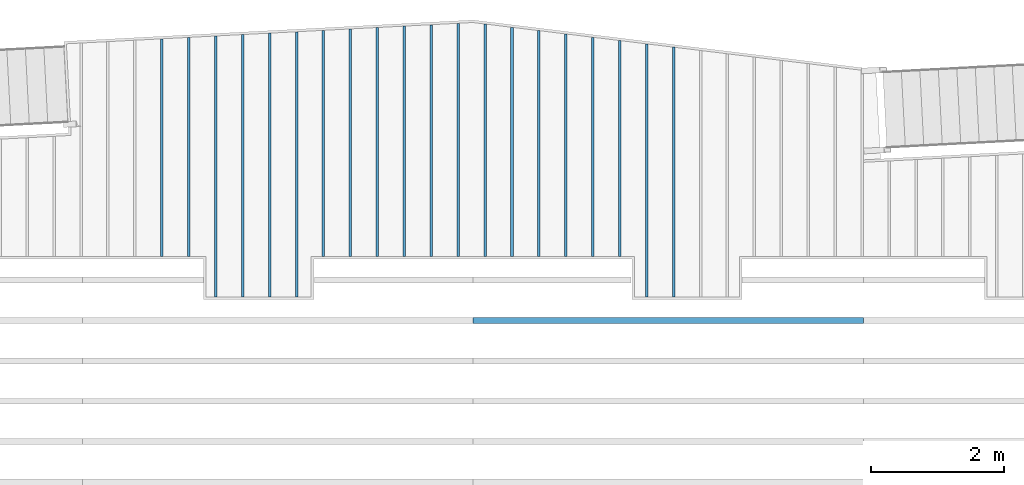
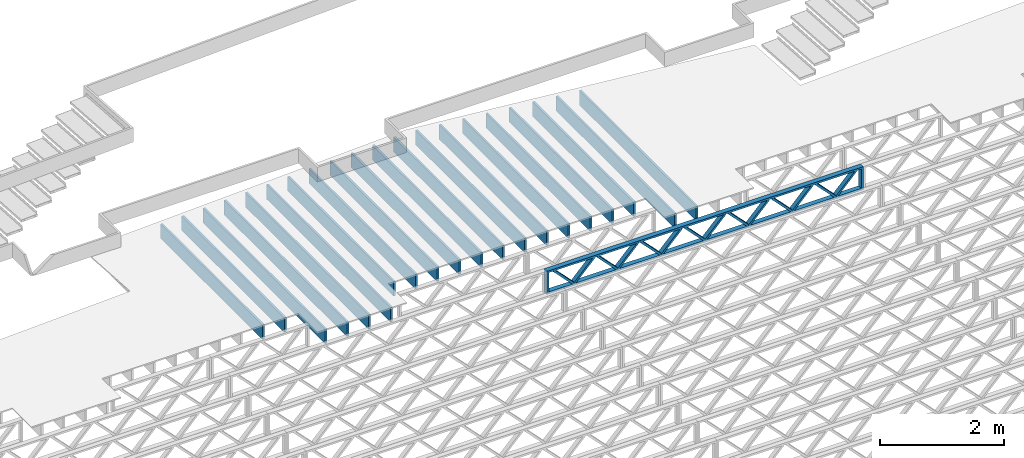
# One storey, part 8 of 23: 21 beams, 2 elements without a shape of their own.
"""IFC4 building model written with IfcOpenShell, lengths in feet."""

from ifc_helpers import new_model, entity, si_unit, converted_unit, derived_unit, direction, frame, frame_2d, origin, origin_2d_with_axis, place, context, subcontext, project, spatial, rectangle, extrude, source, transform, mapped, material, material_profile, profile_set, profile_usage, type_object, type_shapes, element, aggregate, save


model = new_model("IFC4")

# Units and contexts
model_context = context("Model", 3, precision=0.0001, world=origin(), true_north=direction((6.12303176911189e-17, 1.0)))
body_context = subcontext(model_context, "Body", "Model", "MODEL_VIEW")
ifc_project = project(units=[converted_unit("LENGTHUNIT", "FOOT", entity("IfcRatioMeasure", 0.3048), si_unit("LENGTHUNIT", "METRE"), dimensions=[1, 0, 0, 0, 0, 0, 0]), converted_unit("AREAUNIT", "SQUARE FOOT", entity("IfcRatioMeasure", 0.09290304), si_unit("AREAUNIT", "SQUARE_METRE"), dimensions=[2, 0, 0, 0, 0, 0, 0]), converted_unit("VOLUMEUNIT", "CUBIC FOOT", entity("IfcRatioMeasure", 0.028316846592), si_unit("VOLUMEUNIT", "CUBIC_METRE"), dimensions=[3, 0, 0, 0, 0, 0, 0]), converted_unit("PLANEANGLEUNIT", "DEGREE", entity("IfcRatioMeasure", 0.0174532925199433), si_unit("PLANEANGLEUNIT", "RADIAN"), dimensions=[0, 0, 0, 0, 0, 0, 0]), si_unit("MASSUNIT", "GRAM", prefix="KILO"), derived_unit("MASSDENSITYUNIT", [(si_unit("MASSUNIT", "GRAM", prefix="KILO"), 1), (si_unit("LENGTHUNIT", "METRE"), -3)]), derived_unit("MOMENTOFINERTIAUNIT", [(si_unit("LENGTHUNIT", "METRE"), 4)]), si_unit("TIMEUNIT", "SECOND"), si_unit("FREQUENCYUNIT", "HERTZ"), si_unit("THERMODYNAMICTEMPERATUREUNIT", "DEGREE_CELSIUS"), derived_unit("THERMALTRANSMITTANCEUNIT", [(si_unit("MASSUNIT", "GRAM", prefix="KILO"), 1), (si_unit("THERMODYNAMICTEMPERATUREUNIT", "KELVIN"), -1), (si_unit("TIMEUNIT", "SECOND"), -3)]), derived_unit("VOLUMETRICFLOWRATEUNIT", [(si_unit("LENGTHUNIT", "METRE"), 3), (si_unit("TIMEUNIT", "SECOND"), -1)]), si_unit("ELECTRICCURRENTUNIT", "AMPERE"), si_unit("ELECTRICVOLTAGEUNIT", "VOLT"), si_unit("POWERUNIT", "WATT"), si_unit("FORCEUNIT", "NEWTON"), si_unit("ILLUMINANCEUNIT", "LUX"), si_unit("LUMINOUSFLUXUNIT", "LUMEN"), si_unit("LUMINOUSINTENSITYUNIT", "CANDELA"), derived_unit("USERDEFINED", [(si_unit("MASSUNIT", "GRAM", prefix="KILO"), -1), (si_unit("LENGTHUNIT", "METRE"), -2), (si_unit("TIMEUNIT", "SECOND"), 3), (si_unit("LUMINOUSFLUXUNIT", "LUMEN"), 1)]), derived_unit("LINEARVELOCITYUNIT", [(si_unit("LENGTHUNIT", "METRE"), 1), (si_unit("TIMEUNIT", "SECOND"), -1)]), si_unit("PRESSUREUNIT", "PASCAL"), derived_unit("USERDEFINED", [(si_unit("LENGTHUNIT", "METRE"), -2), (si_unit("MASSUNIT", "GRAM", prefix="KILO"), 1), (si_unit("TIMEUNIT", "SECOND"), -2)]), derived_unit("LINEARFORCEUNIT", [(si_unit("MASSUNIT", "GRAM", prefix="KILO"), 1), (si_unit("LENGTHUNIT", "METRE"), 1), (si_unit("TIMEUNIT", "SECOND"), -2), (si_unit("LENGTHUNIT", "METRE"), -1)]), derived_unit("PLANARFORCEUNIT", [(si_unit("MASSUNIT", "GRAM", prefix="KILO"), 1), (si_unit("LENGTHUNIT", "METRE"), 1), (si_unit("TIMEUNIT", "SECOND"), -2), (si_unit("LENGTHUNIT", "METRE"), -2)])], contexts=[model_context])

# Site, building, storey
site_placement = place(None, origin())
site = spatial("IfcSite", under=ifc_project, at=site_placement, CompositionType="ELEMENT")
building_placement = place(site_placement, origin())
building = spatial("IfcBuilding", under=site, at=building_placement, CompositionType="ELEMENT")
storey_placement = place(building_placement, frame((0.0, 0.0, 10.8020833333333)))
storey = spatial("IfcBuildingStorey", under=building, at=storey_placement, Name="2ND FLOOR", CompositionType="ELEMENT", Elevation=10.8020833333333)

# Assembly, beam
assembly_1_placement = place(storey_placement, origin())
assembly_1 = element("IfcElementAssembly", 1, at=assembly_1_placement, inside=storey, Name="Structural Beam System:Structural Framing System", ObjectType="Structural Beam System:Structural Framing System", AssemblyPlace="NOTDEFINED", PredefinedType="BEAM_GRID")
ifc_material_1 = material(Name="WOOD TRUSS", Category="Materials")
ifc_material_profile_1 = material_profile(ifc_material_1, rectangle(XDim=1.73473973950632, YDim=0.125, at=frame_2d((-1.11022302462516e-16, 8.32667268468867e-17), x_axis=(1.0, 0.0))))
ifc_material_profile_2 = material_profile(ifc_material_1, rectangle(XDim=1.73473973950633, YDim=0.125, at=frame_2d((-1.11022302462516e-16, 8.32667268468867e-17), x_axis=(1.0, 0.0))))
ifc_material_profile_3 = material_profile(ifc_material_1, rectangle(XDim=1.73473973950632, YDim=0.125, at=frame_2d((-5.55111512312578e-17, 1.38777878078145e-16), x_axis=(1.0, 0.0))))
ifc_material_profile_4 = material_profile(ifc_material_1, rectangle(XDim=1.73473973950633, YDim=0.125, at=frame_2d((-1.11022302462516e-16, 8.32667268468867e-17), x_axis=(1.0, 0.0))))
ifc_material_profile_5 = material_profile(ifc_material_1, rectangle(XDim=1.73473973950632, YDim=0.125, at=frame_2d((-1.11022302462516e-16, 8.32667268468867e-17), x_axis=(1.0, 0.0))))
ifc_material_profile_6 = material_profile(ifc_material_1, rectangle(XDim=1.73473973950633, YDim=0.125, at=frame_2d((-2.77555756156289e-16, 3.05311331771918e-16), x_axis=(1.0, 0.0))))
ifc_material_profile_7 = material_profile(ifc_material_1, rectangle(XDim=1.73473973950632, YDim=0.124999999999999, at=frame_2d((-3.88578058618805e-16, -2.4980018054066e-16), x_axis=(1.0, 0.0))))
ifc_material_profile_8 = material_profile(ifc_material_1, rectangle(XDim=1.73473973950633, YDim=0.125, at=frame_2d((2.77555756156289e-16, -3.05311331771918e-16), x_axis=(1.0, 0.0))))
ifc_material_profile_9 = material_profile(ifc_material_1, rectangle(XDim=1.73473973950632, YDim=0.124999999999999, at=frame_2d((-1.11022302462516e-16, 8.32667268468867e-17), x_axis=(1.0, 0.0))))
ifc_material_profile_10 = material_profile(ifc_material_1, rectangle(XDim=1.73473973950633, YDim=0.125, at=origin_2d_with_axis()))
ifc_material_profile_11 = material_profile(ifc_material_1, rectangle(XDim=0.124999999999982, YDim=0.291666666666668, at=origin_2d_with_axis()))
ifc_material_profile_12 = material_profile(ifc_material_1, rectangle(XDim=0.124999999999932, YDim=0.291666666666664, at=origin_2d_with_axis()))
ifc_material_profile_13 = material_profile(ifc_material_1, rectangle(XDim=1.25000000000002, YDim=0.29166666666667, at=origin_2d_with_axis()))
ifc_material_profile_14 = material_profile(ifc_material_1, rectangle(XDim=1.25000000000004, YDim=0.291666666666667, at=origin_2d_with_axis()))
ifc_profile_set_1 = profile_set([ifc_material_profile_1, ifc_material_profile_2, ifc_material_profile_3, ifc_material_profile_4, ifc_material_profile_5, ifc_material_profile_6, ifc_material_profile_7, ifc_material_profile_8, ifc_material_profile_9, ifc_material_profile_10, ifc_material_profile_11, ifc_material_profile_12, ifc_material_profile_13, ifc_material_profile_14])
ifc_profile_usage_1 = profile_usage(ifc_profile_set_1, cardinal=8)
beam_type_1 = type_object("IfcBeamType", PredefinedType="BEAM", material=ifc_profile_set_1)
shared_shape_1 = source(origin(), body_context, "Body", "SweptSolid", [
    extrude(rectangle(XDim=1.73473973950632, YDim=0.124999999999999, at=frame_2d((5.55111512312578e-16, 7.21644966006352e-16), x_axis=(1.0, 0.0))), frame((5.95847627016989, -0.145833333333334, 0.0), z_axis=(0.0, 1.0, 0.0), x_axis=(0.693383046997606, 0.0, 0.720569184836762)), (0.0, 0.0, 1.0), 0.291666666666667),
    extrude(rectangle(XDim=1.73473973950633, YDim=0.125, at=origin_2d_with_axis()), frame((4.70819039649662, -0.145833333333334, 0.0), z_axis=(0.0, 1.0, 0.0), x_axis=(0.69338304699761, 0.0, -0.720569184836758)), (0.0, 0.0, 1.0), 0.291666666666666),
    extrude(rectangle(XDim=1.73473973950632, YDim=0.125, at=frame_2d((2.22044604925031e-16, 3.88578058618805e-16), x_axis=(1.0, 0.0))), frame((3.29180960350342, -0.145833333333334, 0.0), z_axis=(0.0, 1.0, 0.0), x_axis=(0.693383046997606, 0.0, 0.720569184836762)), (0.0, 0.0, 1.0), 0.291666666666667),
    extrude(rectangle(XDim=1.73473973950633, YDim=0.125, at=frame_2d((1.11022302462516e-16, -8.32667268468867e-17), x_axis=(1.0, 0.0))), frame((2.04152372983015, -0.145833333333334, 0.0), z_axis=(0.0, 1.0, 0.0), x_axis=(0.69338304699761, 0.0, -0.720569184836758)), (0.0, 0.0, 1.0), 0.291666666666667),
    extrude(rectangle(XDim=1.73473973950632, YDim=0.125, at=frame_2d((-5.55111512312578e-17, 1.38777878078145e-16), x_axis=(1.0, 0.0))), frame((0.625142936836964, -0.145833333333334, 0.0), z_axis=(0.0, 1.0, 0.0), x_axis=(0.693383046997606, 0.0, 0.720569184836762)), (0.0, 0.0, 1.0), 0.291666666666667),
    extrude(rectangle(XDim=1.73473973950633, YDim=0.125, at=frame_2d((-1.11022302462516e-16, 8.32667268468867e-17), x_axis=(1.0, 0.0))), frame((-0.625142936836306, -0.145833333333334, 0.0), z_axis=(0.0, 1.0, 0.0), x_axis=(0.69338304699761, 0.0, -0.720569184836758)), (0.0, 0.0, 1.0), 0.291666666666667),
    extrude(rectangle(XDim=1.73473973950632, YDim=0.125, at=frame_2d((-1.11022302462516e-16, 8.32667268468867e-17), x_axis=(1.0, 0.0))), frame((-2.0415237298295, -0.145833333333334, 0.0), z_axis=(0.0, 1.0, 0.0), x_axis=(0.693383046997606, 0.0, 0.720569184836762)), (0.0, 0.0, 1.0), 0.291666666666667),
    extrude(rectangle(XDim=1.73473973950633, YDim=0.125, at=origin_2d_with_axis()), frame((-3.29180960350277, -0.145833333333334, 0.0), z_axis=(0.0, 1.0, 0.0), x_axis=(0.69338304699761, 0.0, -0.720569184836758)), (0.0, 0.0, 1.0), 0.291666666666667),
    extrude(rectangle(XDim=1.73473973950632, YDim=0.124999999999999, at=frame_2d((-1.11022302462516e-16, 8.32667268468867e-17), x_axis=(1.0, 0.0))), frame((-4.70819039649596, -0.145833333333334, 0.0), z_axis=(0.0, 1.0, 0.0), x_axis=(0.693383046997606, 0.0, 0.720569184836762)), (0.0, 0.0, 1.0), 0.291666666666667),
    extrude(rectangle(XDim=1.73473973950633, YDim=0.125, at=frame_2d((-5.55111512312578e-16, 6.38378239159465e-16), x_axis=(1.0, 0.0))), frame((-5.95847627016923, -0.145833333333334, 0.0), z_axis=(0.0, 1.0, 0.0), x_axis=(0.69338304699761, 0.0, -0.720569184836758)), (0.0, 0.0, 1.0), 0.291666666666666),
    extrude(rectangle(XDim=1.73473973950632, YDim=0.125, at=frame_2d((-7.21644966006352e-16, -5.82867087928207e-16), x_axis=(1.0, 0.0))), frame((8.62514293683635, -0.145833333333334, 0.0), z_axis=(0.0, 1.0, 0.0), x_axis=(0.693383046997607, 0.0, 0.720569184836761)), (0.0, 0.0, 1.0), 0.291666666666667),
    extrude(rectangle(XDim=1.73473973950633, YDim=0.125, at=origin_2d_with_axis()), frame((7.37485706316307, -0.145833333333334, 0.0), z_axis=(0.0, 1.0, 0.0), x_axis=(0.69338304699761, 0.0, -0.720569184836758)), (0.0, 0.0, 1.0), 0.291666666666666),
    extrude(rectangle(XDim=1.73473973950632, YDim=0.124999999999999, at=frame_2d((-1.11022302462516e-16, 8.32667268468867e-17), x_axis=(1.0, 0.0))), frame((-7.37485706316242, -0.145833333333334, 0.0), z_axis=(0.0, 1.0, 0.0), x_axis=(0.693383046997606, 0.0, 0.720569184836762)), (0.0, 0.0, 1.0), 0.291666666666667),
    extrude(rectangle(XDim=1.73473973950633, YDim=0.125, at=origin_2d_with_axis()), frame((-8.62514293683569, -0.145833333333334, 0.0), z_axis=(0.0, 1.0, 0.0), x_axis=(0.69338304699761, 0.0, -0.720569184836758)), (0.0, 0.0, 1.0), 0.291666666666666),
    extrude(rectangle(XDim=0.124999999999982, YDim=0.291666666666668, at=origin_2d_with_axis()), frame((-9.66666666666596, 0.0, 0.687500000000054), z_axis=(1.0, 0.0, 0.0), x_axis=(0.0, 0.0, -1.0)), (0.0, 0.0, 1.0), 19.3333333333319),
    extrude(rectangle(XDim=0.124999999999932, YDim=0.291666666666664, at=origin_2d_with_axis()), frame((-9.66666666666575, 0.0, -0.687499999999984), z_axis=(1.0, 0.0, 0.0), x_axis=(0.0, 0.0, -1.0)), (0.0, 0.0, 1.0), 19.3333333333317),
    extrude(rectangle(XDim=1.25000000000002, YDim=0.29166666666667, at=origin_2d_with_axis()), frame((9.54166666666594, 0.0, 0.0), z_axis=(1.0, 0.0, 0.0), x_axis=(0.0, 0.0, -1.0)), (0.0, 0.0, 1.0), 0.12500000000002),
    extrude(rectangle(XDim=1.25000000000004, YDim=0.291666666666667, at=origin_2d_with_axis()), frame((-9.66666666666596, 0.0, 0.0), z_axis=(1.0, 0.0, 0.0), x_axis=(0.0, 0.0, -1.0)), (0.0, 0.0, 1.0), 0.125000000000023),
])
type_shapes(beam_type_1, [shared_shape_1])
beam_1_placement = place(assembly_1_placement, frame((-193.404827152229, 955.861934882651, -0.947916666666881)))
beam_1 = element("IfcBeam", 2, at=beam_1_placement, type_object=beam_type_1, material=ifc_profile_usage_1, PredefinedType="BEAM", context=body_context, shape_type="MappedRepresentation", body=[
    mapped(shared_shape_1, transform((0.0, 0.0, 0.0), scale=1.0)),
])
aggregate(assembly_1, [beam_1])

# Assembly, beams
assembly_2_placement = place(storey_placement, origin())
assembly_2 = element("IfcElementAssembly", 3, at=assembly_2_placement, inside=storey, Name="Structural Beam System:Structural Framing System", ObjectType="Structural Beam System:Structural Framing System", AssemblyPlace="NOTDEFINED", PredefinedType="BEAM_GRID")
ifc_material_2 = material(Category="Materials")
ifc_material_profile_15 = material_profile(ifc_material_2, rectangle(XDim=0.9375, YDim=0.125000000000011, at=origin_2d_with_axis()))
ifc_profile_set_2 = profile_set([ifc_material_profile_15])
ifc_profile_usage_2 = profile_usage(ifc_profile_set_2, cardinal=8)
beam_type_2 = type_object("IfcBeamType", PredefinedType="BEAM", material=ifc_profile_set_2)
shared_shape_2 = source(origin(), body_context, "Body", "SweptSolid", [
    extrude(rectangle(XDim=0.9375, YDim=0.125000000000011, at=origin_2d_with_axis()), frame((-5.38829312204956, 0.0, 0.0), z_axis=(1.0, 0.0, 0.0), x_axis=(0.0, 0.0, -1.0)), (0.0, 0.0, 1.0), 10.7765862440991),
])
type_shapes(beam_type_2, [shared_shape_2])
beam_2_placement = place(assembly_2_placement, frame((-218.467327152129, 964.41689568793, -0.729166666666744), z_axis=(0.0, 0.0, 1.0), x_axis=(0.0, 1.0, 0.0)))
beam_2 = element("IfcBeam", 4, at=beam_2_placement, type_object=beam_type_2, material=ifc_profile_usage_2, PredefinedType="BEAM", context=body_context, shape_type="MappedRepresentation", body=[
    mapped(shared_shape_2, transform((0.0, 0.0, 0.0), scale=1.0)),
])
ifc_profile_usage_3 = profile_usage(ifc_profile_set_2, cardinal=8)
beam_type_3 = type_object("IfcBeamType", PredefinedType="BEAM", material=ifc_profile_set_2)
shared_shape_3 = source(origin(), body_context, "Body", "SweptSolid", [
    extrude(rectangle(XDim=0.9375, YDim=0.125000000000011, at=origin_2d_with_axis()), frame((-5.42303803630836, 0.0, 0.0), z_axis=(1.0, 0.0, 0.0), x_axis=(0.0, 0.0, -1.0)), (0.0, 0.0, 1.0), 10.8460760726167),
])
type_shapes(beam_type_3, [shared_shape_3])
beam_3_placement = place(assembly_2_placement, frame((-217.133993818795, 964.451640285195, -0.729166666666744), z_axis=(0.0, 0.0, 1.0), x_axis=(0.0, 1.0, 0.0)))
beam_3 = element("IfcBeam", 5, at=beam_3_placement, type_object=beam_type_3, material=ifc_profile_usage_3, PredefinedType="BEAM", context=body_context, shape_type="MappedRepresentation", body=[
    mapped(shared_shape_3, transform((0.0, 0.0, 0.0), scale=1.0)),
])
ifc_profile_usage_4 = profile_usage(ifc_profile_set_2, cardinal=8)
beam_type_4 = type_object("IfcBeamType", PredefinedType="BEAM", material=ifc_profile_set_2)
shared_shape_4 = source(origin(), body_context, "Body", "SweptSolid", [
    extrude(rectangle(XDim=0.9375, YDim=0.125000000000011, at=origin_2d_with_axis()), frame((-6.45778314185435, 0.0, 0.0), z_axis=(1.0, 0.0, 0.0), x_axis=(0.0, 0.0, -1.0)), (0.0, 0.0, 1.0), 12.9155662837087),
])
type_shapes(beam_type_4, [shared_shape_4])
beam_4_placement = place(assembly_2_placement, frame((-215.800660485462, 963.486384691172, -0.729166666666744), z_axis=(0.0, 0.0, 1.0), x_axis=(0.0, 1.0, 0.0)))
beam_4 = element("IfcBeam", 6, at=beam_4_placement, type_object=beam_type_4, material=ifc_profile_usage_4, PredefinedType="BEAM", context=body_context, shape_type="MappedRepresentation", body=[
    mapped(shared_shape_4, transform((0.0, 0.0, 0.0), scale=1.0)),
])
ifc_profile_usage_5 = profile_usage(ifc_profile_set_2, cardinal=8)
beam_type_5 = type_object("IfcBeamType", PredefinedType="BEAM", material=ifc_profile_set_2)
shared_shape_5 = source(origin(), body_context, "Body", "SweptSolid", [
    extrude(rectangle(XDim=0.9375, YDim=0.125000000000011, at=origin_2d_with_axis()), frame((-6.49252789761618, 0.0, 0.0), z_axis=(1.0, 0.0, 0.0), x_axis=(0.0, 0.0, -1.0)), (0.0, 0.0, 1.0), 12.9850557952324),
])
type_shapes(beam_type_5, [shared_shape_5])
beam_5_placement = place(assembly_2_placement, frame((-214.467327152129, 963.521129446934, -0.729166666666744), z_axis=(0.0, 0.0, 1.0), x_axis=(0.0, 1.0, 0.0)))
beam_5 = element("IfcBeam", 7, at=beam_5_placement, type_object=beam_type_5, material=ifc_profile_usage_5, PredefinedType="BEAM", context=body_context, shape_type="MappedRepresentation", body=[
    mapped(shared_shape_5, transform((0.0, 0.0, 0.0), scale=1.0)),
])
ifc_profile_usage_6 = profile_usage(ifc_profile_set_2, cardinal=8)
beam_type_6 = type_object("IfcBeamType", PredefinedType="BEAM", material=ifc_profile_set_2)
shared_shape_6 = source(origin(), body_context, "Body", "SweptSolid", [
    extrude(rectangle(XDim=0.9375, YDim=0.125000000000011, at=origin_2d_with_axis()), frame((-6.52727265337796, 0.0, 0.0), z_axis=(1.0, 0.0, 0.0), x_axis=(0.0, 0.0, -1.0)), (0.0, 0.0, 1.0), 13.0545453067559),
])
type_shapes(beam_type_6, [shared_shape_6])
beam_6_placement = place(assembly_2_placement, frame((-213.133993818795, 963.555874202696, -0.729166666666744), z_axis=(0.0, 0.0, 1.0), x_axis=(0.0, 1.0, 0.0)))
beam_6 = element("IfcBeam", 8, at=beam_6_placement, type_object=beam_type_6, material=ifc_profile_usage_6, PredefinedType="BEAM", context=body_context, shape_type="MappedRepresentation", body=[
    mapped(shared_shape_6, transform((0.0, 0.0, 0.0), scale=1.0)),
])
ifc_profile_usage_7 = profile_usage(ifc_profile_set_2, cardinal=8)
beam_type_7 = type_object("IfcBeamType", PredefinedType="BEAM", material=ifc_profile_set_2)
shared_shape_7 = source(origin(), body_context, "Body", "SweptSolid", [
    extrude(rectangle(XDim=0.9375, YDim=0.125000000000011, at=origin_2d_with_axis()), frame((-6.56201740913974, 0.0, 0.0), z_axis=(1.0, 0.0, 0.0), x_axis=(0.0, 0.0, -1.0)), (0.0, 0.0, 1.0), 13.1240348182795),
])
type_shapes(beam_type_7, [shared_shape_7])
beam_7_placement = place(assembly_2_placement, frame((-211.800660485462, 963.590618958458, -0.729166666666744), z_axis=(0.0, 0.0, 1.0), x_axis=(0.0, 1.0, 0.0)))
beam_7 = element("IfcBeam", 9, at=beam_7_placement, type_object=beam_type_7, material=ifc_profile_usage_7, PredefinedType="BEAM", context=body_context, shape_type="MappedRepresentation", body=[
    mapped(shared_shape_7, transform((0.0, 0.0, 0.0), scale=1.0)),
])
ifc_profile_usage_8 = profile_usage(ifc_profile_set_2, cardinal=8)
beam_type_8 = type_object("IfcBeamType", PredefinedType="BEAM", material=ifc_profile_set_2)
shared_shape_8 = source(origin(), body_context, "Body", "SweptSolid", [
    extrude(rectangle(XDim=0.9375, YDim=0.125000000000011, at=origin_2d_with_axis()), frame((-5.59676245292826, 0.0, 0.0), z_axis=(1.0, 0.0, 0.0), x_axis=(0.0, 0.0, -1.0)), (0.0, 0.0, 1.0), 11.1935249058565),
])
type_shapes(beam_type_8, [shared_shape_8])
beam_8_placement = place(assembly_2_placement, frame((-210.467327152129, 964.625363426193, -0.729166666666744), z_axis=(0.0, 0.0, 1.0), x_axis=(0.0, 1.0, 0.0)))
beam_8 = element("IfcBeam", 10, at=beam_8_placement, type_object=beam_type_8, material=ifc_profile_usage_8, PredefinedType="BEAM", context=body_context, shape_type="MappedRepresentation", body=[
    mapped(shared_shape_8, transform((0.0, 0.0, 0.0), scale=1.0)),
])
ifc_profile_usage_9 = profile_usage(ifc_profile_set_2, cardinal=8)
beam_type_9 = type_object("IfcBeamType", PredefinedType="BEAM", material=ifc_profile_set_2)
shared_shape_9 = source(origin(), body_context, "Body", "SweptSolid", [
    extrude(rectangle(XDim=0.9375, YDim=0.125000000000011, at=origin_2d_with_axis()), frame((-5.63150704118897, 0.0, 0.0), z_axis=(1.0, 0.0, 0.0), x_axis=(0.0, 0.0, -1.0)), (0.0, 0.0, 1.0), 11.2630140823779),
])
type_shapes(beam_type_9, [shared_shape_9])
beam_9_placement = place(assembly_2_placement, frame((-209.133993818795, 964.660108349456, -0.729166666666744), z_axis=(0.0, 0.0, 1.0), x_axis=(0.0, 1.0, 0.0)))
beam_9 = element("IfcBeam", 11, at=beam_9_placement, type_object=beam_type_9, material=ifc_profile_usage_9, PredefinedType="BEAM", context=body_context, shape_type="MappedRepresentation", body=[
    mapped(shared_shape_9, transform((0.0, 0.0, 0.0), scale=1.0)),
])
ifc_profile_usage_10 = profile_usage(ifc_profile_set_2, cardinal=8)
beam_type_10 = type_object("IfcBeamType", PredefinedType="BEAM", material=ifc_profile_set_2)
shared_shape_10 = source(origin(), body_context, "Body", "SweptSolid", [
    extrude(rectangle(XDim=0.9375, YDim=0.125000000000011, at=origin_2d_with_axis()), frame((-5.66625162944956, 0.0, 0.0), z_axis=(1.0, 0.0, 0.0), x_axis=(0.0, 0.0, -1.0)), (0.0, 0.0, 1.0), 11.3325032588991),
])
type_shapes(beam_type_10, [shared_shape_10])
beam_10_placement = place(assembly_2_placement, frame((-207.800660485462, 964.694853272719, -0.729166666666744), z_axis=(0.0, 0.0, 1.0), x_axis=(0.0, 1.0, 0.0)))
beam_10 = element("IfcBeam", 12, at=beam_10_placement, type_object=beam_type_10, material=ifc_profile_usage_10, PredefinedType="BEAM", context=body_context, shape_type="MappedRepresentation", body=[
    mapped(shared_shape_10, transform((0.0, 0.0, 0.0), scale=1.0)),
])
ifc_profile_usage_11 = profile_usage(ifc_profile_set_2, cardinal=8)
beam_type_11 = type_object("IfcBeamType", PredefinedType="BEAM", material=ifc_profile_set_2)
shared_shape_11 = source(origin(), body_context, "Body", "SweptSolid", [
    extrude(rectangle(XDim=0.9375, YDim=0.125000000000011, at=origin_2d_with_axis()), frame((-5.70099621771021, 0.0, 0.0), z_axis=(1.0, 0.0, 0.0), x_axis=(0.0, 0.0, -1.0)), (0.0, 0.0, 1.0), 11.4019924354204),
])
type_shapes(beam_type_11, [shared_shape_11])
beam_11_placement = place(assembly_2_placement, frame((-206.467327152129, 964.729598195982, -0.729166666666744), z_axis=(0.0, 0.0, 1.0), x_axis=(0.0, 1.0, 0.0)))
beam_11 = element("IfcBeam", 13, at=beam_11_placement, type_object=beam_type_11, material=ifc_profile_usage_11, PredefinedType="BEAM", context=body_context, shape_type="MappedRepresentation", body=[
    mapped(shared_shape_11, transform((0.0, 0.0, 0.0), scale=1.0)),
])
ifc_profile_usage_12 = profile_usage(ifc_profile_set_2, cardinal=8)
beam_type_12 = type_object("IfcBeamType", PredefinedType="BEAM", material=ifc_profile_set_2)
shared_shape_12 = source(origin(), body_context, "Body", "SweptSolid", [
    extrude(rectangle(XDim=0.9375, YDim=0.125000000000011, at=origin_2d_with_axis()), frame((-5.73574080597081, 0.0, 0.0), z_axis=(1.0, 0.0, 0.0), x_axis=(0.0, 0.0, -1.0)), (0.0, 0.0, 1.0), 11.4714816119416),
])
type_shapes(beam_type_12, [shared_shape_12])
beam_12_placement = place(assembly_2_placement, frame((-205.133993818795, 964.764343119245, -0.729166666666744), z_axis=(0.0, 0.0, 1.0), x_axis=(0.0, 1.0, 0.0)))
beam_12 = element("IfcBeam", 14, at=beam_12_placement, type_object=beam_type_12, material=ifc_profile_usage_12, PredefinedType="BEAM", context=body_context, shape_type="MappedRepresentation", body=[
    mapped(shared_shape_12, transform((0.0, 0.0, 0.0), scale=1.0)),
])
ifc_profile_usage_13 = profile_usage(ifc_profile_set_2, cardinal=8)
beam_type_13 = type_object("IfcBeamType", PredefinedType="BEAM", material=ifc_profile_set_2)
shared_shape_13 = source(origin(), body_context, "Body", "SweptSolid", [
    extrude(rectangle(XDim=0.9375, YDim=0.125000000000011, at=origin_2d_with_axis()), frame((-5.77048539423151, 0.0, 0.0), z_axis=(1.0, 0.0, 0.0), x_axis=(0.0, 0.0, -1.0)), (0.0, 0.0, 1.0), 11.540970788463),
])
type_shapes(beam_type_13, [shared_shape_13])
beam_13_placement = place(assembly_2_placement, frame((-203.800660485462, 964.799088042507, -0.729166666666744), z_axis=(0.0, 0.0, 1.0), x_axis=(0.0, 1.0, 0.0)))
beam_13 = element("IfcBeam", 15, at=beam_13_placement, type_object=beam_type_13, material=ifc_profile_usage_13, PredefinedType="BEAM", context=body_context, shape_type="MappedRepresentation", body=[
    mapped(shared_shape_13, transform((0.0, 0.0, 0.0), scale=1.0)),
])
ifc_profile_usage_14 = profile_usage(ifc_profile_set_2, cardinal=8)
beam_type_14 = type_object("IfcBeamType", PredefinedType="BEAM", material=ifc_profile_set_2)
shared_shape_14 = source(origin(), body_context, "Body", "SweptSolid", [
    extrude(rectangle(XDim=0.9375, YDim=0.125000000000011, at=origin_2d_with_axis()), frame((-5.7535228382128, 0.0, 0.0), z_axis=(1.0, 0.0, 0.0), x_axis=(0.0, 0.0, -1.0)), (0.0, 0.0, 1.0), 11.5070456764256),
])
type_shapes(beam_type_14, [shared_shape_14])
beam_14_placement = place(assembly_2_placement, frame((-202.467327152129, 964.782125821491, -0.729166666666744), z_axis=(0.0, 0.0, 1.0), x_axis=(0.0, 1.0, 0.0)))
beam_14 = element("IfcBeam", 16, at=beam_14_placement, type_object=beam_type_14, material=ifc_profile_usage_14, PredefinedType="BEAM", context=body_context, shape_type="MappedRepresentation", body=[
    mapped(shared_shape_14, transform((0.0, 0.0, 0.0), scale=1.0)),
])
ifc_profile_usage_15 = profile_usage(ifc_profile_set_2, cardinal=8)
beam_type_15 = type_object("IfcBeamType", PredefinedType="BEAM", material=ifc_profile_set_2)
shared_shape_15 = source(origin(), body_context, "Body", "SweptSolid", [
    extrude(rectangle(XDim=0.9375, YDim=0.125000000000011, at=origin_2d_with_axis()), frame((-5.67166629677644, 0.0, 0.0), z_axis=(1.0, 0.0, 0.0), x_axis=(0.0, 0.0, -1.0)), (0.0, 0.0, 1.0), 11.3433325935529),
])
type_shapes(beam_type_15, [shared_shape_15])
beam_15_placement = place(assembly_2_placement, frame((-201.133993818795, 964.700269615057, -0.729166666666744), z_axis=(0.0, 0.0, 1.0), x_axis=(0.0, 1.0, 0.0)))
beam_15 = element("IfcBeam", 17, at=beam_15_placement, type_object=beam_type_15, material=ifc_profile_usage_15, PredefinedType="BEAM", context=body_context, shape_type="MappedRepresentation", body=[
    mapped(shared_shape_15, transform((0.0, 0.0, 0.0), scale=1.0)),
])
ifc_profile_usage_16 = profile_usage(ifc_profile_set_2, cardinal=8)
beam_type_16 = type_object("IfcBeamType", PredefinedType="BEAM", material=ifc_profile_set_2)
shared_shape_16 = source(origin(), body_context, "Body", "SweptSolid", [
    extrude(rectangle(XDim=0.9375, YDim=0.125000000000011, at=origin_2d_with_axis()), frame((-5.58980975533996, 0.0, 0.0), z_axis=(1.0, 0.0, 0.0), x_axis=(0.0, 0.0, -1.0)), (0.0, 0.0, 1.0), 11.1796195106799),
])
type_shapes(beam_type_16, [shared_shape_16])
beam_16_placement = place(assembly_2_placement, frame((-199.800660485462, 964.618413408623, -0.729166666666744), z_axis=(0.0, 0.0, 1.0), x_axis=(0.0, 1.0, 0.0)))
beam_16 = element("IfcBeam", 18, at=beam_16_placement, type_object=beam_type_16, material=ifc_profile_usage_16, PredefinedType="BEAM", context=body_context, shape_type="MappedRepresentation", body=[
    mapped(shared_shape_16, transform((0.0, 0.0, 0.0), scale=1.0)),
])
ifc_profile_usage_17 = profile_usage(ifc_profile_set_2, cardinal=8)
beam_type_17 = type_object("IfcBeamType", PredefinedType="BEAM", material=ifc_profile_set_2)
shared_shape_17 = source(origin(), body_context, "Body", "SweptSolid", [
    extrude(rectangle(XDim=0.9375, YDim=0.125000000000011, at=origin_2d_with_axis()), frame((-5.50795321390359, 0.0, 0.0), z_axis=(1.0, 0.0, 0.0), x_axis=(0.0, 0.0, -1.0)), (0.0, 0.0, 1.0), 11.0159064278072),
])
type_shapes(beam_type_17, [shared_shape_17])
beam_17_placement = place(assembly_2_placement, frame((-198.467327152129, 964.536557202189, -0.729166666666744), z_axis=(0.0, 0.0, 1.0), x_axis=(0.0, 1.0, 0.0)))
beam_17 = element("IfcBeam", 19, at=beam_17_placement, type_object=beam_type_17, material=ifc_profile_usage_17, PredefinedType="BEAM", context=body_context, shape_type="MappedRepresentation", body=[
    mapped(shared_shape_17, transform((0.0, 0.0, 0.0), scale=1.0)),
])
ifc_profile_usage_18 = profile_usage(ifc_profile_set_2, cardinal=8)
beam_type_18 = type_object("IfcBeamType", PredefinedType="BEAM", material=ifc_profile_set_2)
shared_shape_18 = source(origin(), body_context, "Body", "SweptSolid", [
    extrude(rectangle(XDim=0.9375, YDim=0.125000000000011, at=origin_2d_with_axis()), frame((-5.42609667246711, 0.0, 0.0), z_axis=(1.0, 0.0, 0.0), x_axis=(0.0, 0.0, -1.0)), (0.0, 0.0, 1.0), 10.8521933449342),
])
type_shapes(beam_type_18, [shared_shape_18])
beam_18_placement = place(assembly_2_placement, frame((-197.133993818795, 964.454700995755, -0.729166666666744), z_axis=(0.0, 0.0, 1.0), x_axis=(0.0, 1.0, 0.0)))
beam_18 = element("IfcBeam", 20, at=beam_18_placement, type_object=beam_type_18, material=ifc_profile_usage_18, PredefinedType="BEAM", context=body_context, shape_type="MappedRepresentation", body=[
    mapped(shared_shape_18, transform((0.0, 0.0, 0.0), scale=1.0)),
])
ifc_profile_usage_19 = profile_usage(ifc_profile_set_2, cardinal=8)
beam_type_19 = type_object("IfcBeamType", PredefinedType="BEAM", material=ifc_profile_set_2)
shared_shape_19 = source(origin(), body_context, "Body", "SweptSolid", [
    extrude(rectangle(XDim=0.9375, YDim=0.125000000000011, at=origin_2d_with_axis()), frame((-5.34424013103074, 0.0, 0.0), z_axis=(1.0, 0.0, 0.0), x_axis=(0.0, 0.0, -1.0)), (0.0, 0.0, 1.0), 10.6884802620615),
])
type_shapes(beam_type_19, [shared_shape_19])
beam_19_placement = place(assembly_2_placement, frame((-195.800660485462, 964.372844789321, -0.729166666666744), z_axis=(0.0, 0.0, 1.0), x_axis=(0.0, 1.0, 0.0)))
beam_19 = element("IfcBeam", 21, at=beam_19_placement, type_object=beam_type_19, material=ifc_profile_usage_19, PredefinedType="BEAM", context=body_context, shape_type="MappedRepresentation", body=[
    mapped(shared_shape_19, transform((0.0, 0.0, 0.0), scale=1.0)),
])
ifc_profile_usage_20 = profile_usage(ifc_profile_set_2, cardinal=8)
beam_type_20 = type_object("IfcBeamType", PredefinedType="BEAM", material=ifc_profile_set_2)
shared_shape_20 = source(origin(), body_context, "Body", "SweptSolid", [
    extrude(rectangle(XDim=0.9375, YDim=0.125000000000011, at=origin_2d_with_axis()), frame((-6.26238531158162, 0.0, 0.0), z_axis=(1.0, 0.0, 0.0), x_axis=(0.0, 0.0, -1.0)), (0.0, 0.0, 1.0), 12.5247706231632),
])
type_shapes(beam_type_20, [shared_shape_20])
beam_20_placement = place(assembly_2_placement, frame((-194.467327152129, 963.290986860899, -0.729166666666744), z_axis=(0.0, 0.0, 1.0), x_axis=(0.0, 1.0, 0.0)))
beam_20 = element("IfcBeam", 22, at=beam_20_placement, type_object=beam_type_20, material=ifc_profile_usage_20, PredefinedType="BEAM", context=body_context, shape_type="MappedRepresentation", body=[
    mapped(shared_shape_20, transform((0.0, 0.0, 0.0), scale=1.0)),
])
ifc_profile_usage_21 = profile_usage(ifc_profile_set_2, cardinal=8)
beam_type_21 = type_object("IfcBeamType", PredefinedType="BEAM", material=ifc_profile_set_2)
shared_shape_21 = source(origin(), body_context, "Body", "SweptSolid", [
    extrude(rectangle(XDim=0.9375, YDim=0.125000000000011, at=origin_2d_with_axis()), frame((-6.18052893764639, 0.0, 0.0), z_axis=(1.0, 0.0, 0.0), x_axis=(0.0, 0.0, -1.0)), (0.0, 0.0, 1.0), 12.3610578752928),
])
type_shapes(beam_type_21, [shared_shape_21])
beam_21_placement = place(assembly_2_placement, frame((-193.133993818795, 963.209130486964, -0.729166666666744), z_axis=(0.0, 0.0, 1.0), x_axis=(0.0, 1.0, 0.0)))
beam_21 = element("IfcBeam", 23, at=beam_21_placement, type_object=beam_type_21, material=ifc_profile_usage_21, PredefinedType="BEAM", context=body_context, shape_type="MappedRepresentation", body=[
    mapped(shared_shape_21, transform((0.0, 0.0, 0.0), scale=1.0)),
])
aggregate(assembly_2, [beam_2, beam_3, beam_4, beam_5, beam_6, beam_7, beam_8, beam_9, beam_10, beam_11, beam_12, beam_13, beam_14, beam_15, beam_16, beam_17, beam_18, beam_19, beam_20, beam_21])

save(model, "model.ifc")
